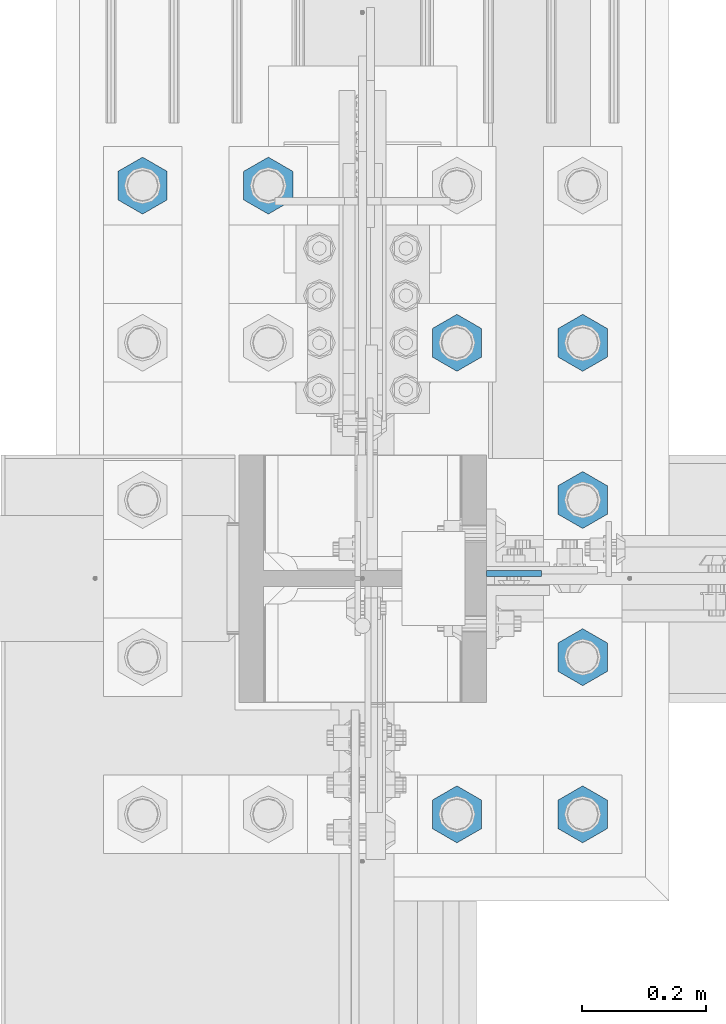
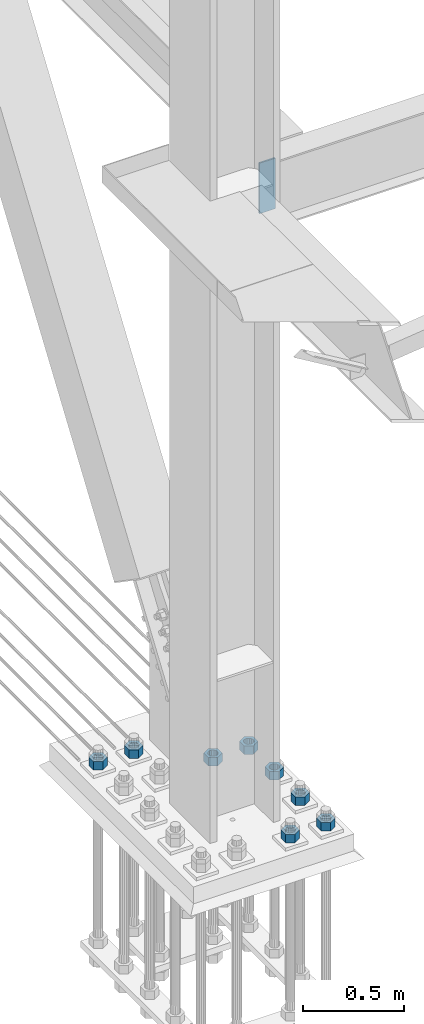
# One storey, part 1548 of 3843: 9 columns, 2 elements without a shape of their own.
"""IFC2X3 building model written with IfcOpenShell, lengths in millimetres."""

from ifc_helpers import new_model, si_unit, frame, origin_with_axes, place, context, subcontext, project, spatial, faceted_brep, material, type_object, element, aggregate, save


model = new_model("IFC2X3")

# Units and contexts
model_context = context("Model", 3, precision=1e-05, world=origin_with_axes())
body_context = subcontext(model_context, "Body", "Model", "MODEL_VIEW")
ifc_project = project(units=[si_unit("LENGTHUNIT", "METRE", prefix="MILLI"), si_unit("AREAUNIT", "SQUARE_METRE"), si_unit("VOLUMEUNIT", "CUBIC_METRE"), si_unit("MASSUNIT", "GRAM", prefix="KILO"), si_unit("TIMEUNIT", "SECOND"), si_unit("PLANEANGLEUNIT", "RADIAN"), si_unit("SOLIDANGLEUNIT", "STERADIAN"), si_unit("THERMODYNAMICTEMPERATUREUNIT", "DEGREE_CELSIUS"), si_unit("LUMINOUSINTENSITYUNIT", "LUMEN")], contexts=[model_context])

# Site, building, storey
site_placement = place(None, origin_with_axes())
site = spatial("IfcSite", under=ifc_project, at=site_placement, CompositionType="ELEMENT")
building_placement = place(site_placement, origin_with_axes())
building = spatial("IfcBuilding", under=site, at=building_placement, Name="Undefined", CompositionType="ELEMENT")
storey_placement = place(building_placement, origin_with_axes())
storey = spatial("IfcBuildingStorey", under=building, at=storey_placement, Name="Undefined", CompositionType="ELEMENT", Elevation=0.0)

# Assembly, column
assembly_1_placement = place(storey_placement, origin_with_axes())
assembly_1 = element("IfcElementAssembly", 1, at=assembly_1_placement, inside=storey, Name="COLUMN", AssemblyPlace="NOTDEFINED", PredefinedType="RIGID_FRAME")
ifc_material = material(Name="STEEL/A572-50")
column_type_1 = type_object("IfcColumnType", PredefinedType="NOTDEFINED")
column_1_placement = place(assembly_1_placement, frame((36820.475, 67279.8375, 33693.0999993376), z_axis=(-1.0, 0.0, 0.0), x_axis=(0.0, 0.0, 1.0)))
column_1 = element("IfcColumn", 2, at=column_1_placement, type_object=column_type_1, material=ifc_material, Name="PLATE", context=body_context, shape_type="Brep", body=[
    faceted_brep([(0.0, 4.76249999999709, -44.4500000000007), (0.0, 4.76249999999709, 44.4500000000007), (304.799999999996, 4.76249999999709, 44.4500000000007), (304.799999999996, 4.76249999999709, -44.4500000000007), (0.0, -4.76249999999709, 44.4500000000007), (304.799999999996, -4.76249999999709, 44.4500000000007), (0.0, -4.76249999999709, -44.4500000000007), (304.799999999996, -4.76249999999709, -44.4500000000007)], [[[0, 1, 2, 3]], [[1, 4, 5, 2]], [[4, 6, 7, 5]], [[6, 0, 3, 7]], [[5, 7, 3, 2]], [[6, 4, 1, 0]]]),
])
aggregate(assembly_1, [column_1])

# Assembly, columns
assembly_2_placement = place(storey_placement, origin_with_axes())
assembly_2 = element("IfcElementAssembly", 3, at=assembly_2_placement, inside=storey, Name="TEMPLATE", AssemblyPlace="NOTDEFINED", PredefinedType="RIGID_FRAME")
column_type_2 = type_object("IfcColumnType", Name="2_HEAVY_HEX_NUT", PredefinedType="NOTDEFINED")
column_2_placement = place(assembly_2_placement, frame((36931.6, 66890.9, 30232.35), z_axis=(1.0, 0.0, 0.0), x_axis=(0.0, 0.0, -1.0)))
column_2 = element("IfcColumn", 4, at=column_2_placement, type_object=column_type_2, material=ifc_material, Name="NUT", ObjectType="2_HEAVY_HEX_NUT", context=body_context, shape_type="Brep", body=[
    faceted_brep([(0.0, -46.0369987487793, 0.0), (0.0, -23.0184993743896, -39.869213104248), (50.7999999999993, -23.0184993743896, -39.869213104248), (50.7999999999993, -46.0369987487793, 0.0), (0.0, 23.0184993743896, -39.869213104248), (50.7999999999993, 23.0184993743896, -39.869213104248), (0.0, 46.0369987487793, 0.0), (50.7999999999993, 46.0369987487793, 0.0), (0.0, 23.0184993743896, 39.869213104248), (50.7999999999993, 23.0184993743896, 39.869213104248), (0.0, -23.0184993743896, 39.869213104248), (50.7999999999993, -23.0184993743896, 39.869213104248), (0.0, 0.0, 26.1940002441406), (0.0, 11.3650617044477, 23.5999013092805), (50.7999999999993, 11.3650617044477, 23.5999013092805), (50.7999999999993, 0.0, 26.1940002441406), (0.0, 20.4791109456419, 16.3316083006721), (50.7999999999993, 20.4791109456419, 16.3316083006721), (0.0, 25.5370200498292, 5.82867859874386), (50.7999999999993, 25.5370200498292, 5.82867859874386), (0.0, 25.5370200498292, -5.82867859874386), (50.7999999999993, 25.5370200498292, -5.82867859874386), (0.0, 20.4791109456419, -16.3316083006721), (50.7999999999993, 20.4791109456419, -16.3316083006721), (0.0, 11.3650617044477, -23.5999013092805), (50.7999999999993, 11.3650617044477, -23.5999013092805), (0.0, 0.0, -26.1940002441406), (50.7999999999993, 0.0, -26.1940002441406), (0.0, -11.3650617044477, -23.5999013092805), (50.7999999999993, -11.3650617044477, -23.5999013092805), (0.0, -20.4791109456419, -16.3316083006721), (50.7999999999993, -20.4791109456419, -16.3316083006721), (0.0, -25.5370200498292, -5.82867859874386), (50.7999999999993, -25.5370200498292, -5.82867859874386), (0.0, -25.5370200498292, 5.82867859874386), (50.7999999999993, -25.5370200498292, 5.82867859874386), (0.0, -20.4791109456419, 16.3316083006721), (50.7999999999993, -20.4791109456419, 16.3316083006721), (0.0, -11.3650617044477, 23.5999013092805), (50.7999999999993, -11.3650617044477, 23.5999013092805)], [[[0, 1, 2, 3]], [[1, 4, 5, 2]], [[4, 6, 7, 5]], [[6, 8, 9, 7]], [[8, 10, 11, 9]], [[10, 0, 3, 11]], [[12, 13, 14, 15]], [[13, 16, 17, 14]], [[16, 18, 19, 17]], [[18, 20, 21, 19]], [[20, 22, 23, 21]], [[22, 24, 25, 23]], [[24, 26, 27, 25]], [[26, 28, 29, 27]], [[28, 30, 31, 29]], [[30, 32, 33, 31]], [[32, 34, 35, 33]], [[34, 36, 37, 35]], [[36, 38, 39, 37]], [[38, 12, 15, 39]], [[5, 7, 9, 11, 3, 2], [17, 19, 21, 23, 25, 27, 29, 31, 33, 35, 37, 39, 15, 14]], [[10, 8, 6, 4, 1, 0], [38, 36, 34, 32, 30, 28, 26, 24, 22, 20, 18, 16, 13, 12]]]),
])
column_3_placement = place(assembly_2_placement, frame((36931.6, 67144.9, 30232.35), z_axis=(1.0, 0.0, 0.0), x_axis=(0.0, 0.0, -1.0)))
column_3 = element("IfcColumn", 5, at=column_3_placement, type_object=column_type_2, material=ifc_material, Name="NUT", ObjectType="2_HEAVY_HEX_NUT", context=body_context, shape_type="Brep", body=[
    faceted_brep([(0.0, -46.0369987487793, 0.0), (0.0, -23.0184993743896, -39.869213104248), (50.7999999999993, -23.0184993743896, -39.869213104248), (50.7999999999993, -46.0369987487793, 0.0), (0.0, 23.0184993743896, -39.869213104248), (50.7999999999993, 23.0184993743896, -39.869213104248), (0.0, 46.0369987487793, 0.0), (50.7999999999993, 46.0369987487793, 0.0), (0.0, 23.0184993743896, 39.869213104248), (50.7999999999993, 23.0184993743896, 39.869213104248), (0.0, -23.0184993743896, 39.869213104248), (50.7999999999993, -23.0184993743896, 39.869213104248), (0.0, 0.0, 26.1940002441406), (0.0, 11.3650617044477, 23.5999013092805), (50.7999999999993, 11.3650617044477, 23.5999013092805), (50.7999999999993, 0.0, 26.1940002441406), (0.0, 20.4791109456419, 16.3316083006721), (50.7999999999993, 20.4791109456419, 16.3316083006721), (0.0, 25.5370200498292, 5.82867859874386), (50.7999999999993, 25.5370200498292, 5.82867859874386), (0.0, 25.5370200498292, -5.82867859874386), (50.7999999999993, 25.5370200498292, -5.82867859874386), (0.0, 20.4791109456419, -16.3316083006721), (50.7999999999993, 20.4791109456419, -16.3316083006721), (0.0, 11.3650617044477, -23.5999013092805), (50.7999999999993, 11.3650617044477, -23.5999013092805), (0.0, 0.0, -26.1940002441406), (50.7999999999993, 0.0, -26.1940002441406), (0.0, -11.3650617044477, -23.5999013092805), (50.7999999999993, -11.3650617044477, -23.5999013092805), (0.0, -20.4791109456419, -16.3316083006721), (50.7999999999993, -20.4791109456419, -16.3316083006721), (0.0, -25.5370200498292, -5.82867859874386), (50.7999999999993, -25.5370200498292, -5.82867859874386), (0.0, -25.5370200498292, 5.82867859874386), (50.7999999999993, -25.5370200498292, 5.82867859874386), (0.0, -20.4791109456419, 16.3316083006721), (50.7999999999993, -20.4791109456419, 16.3316083006721), (0.0, -11.3650617044477, 23.5999013092805), (50.7999999999993, -11.3650617044477, 23.5999013092805)], [[[0, 1, 2, 3]], [[1, 4, 5, 2]], [[4, 6, 7, 5]], [[6, 8, 9, 7]], [[8, 10, 11, 9]], [[10, 0, 3, 11]], [[12, 13, 14, 15]], [[13, 16, 17, 14]], [[16, 18, 19, 17]], [[18, 20, 21, 19]], [[20, 22, 23, 21]], [[22, 24, 25, 23]], [[24, 26, 27, 25]], [[26, 28, 29, 27]], [[28, 30, 31, 29]], [[30, 32, 33, 31]], [[32, 34, 35, 33]], [[34, 36, 37, 35]], [[36, 38, 39, 37]], [[38, 12, 15, 39]], [[5, 7, 9, 11, 3, 2], [17, 19, 21, 23, 25, 27, 29, 31, 33, 35, 37, 39, 15, 14]], [[10, 8, 6, 4, 1, 0], [38, 36, 34, 32, 30, 28, 26, 24, 22, 20, 18, 16, 13, 12]]]),
])
column_4_placement = place(assembly_2_placement, frame((36931.6, 67398.9, 30232.35), z_axis=(1.0, 0.0, 0.0), x_axis=(0.0, 0.0, -1.0)))
column_4 = element("IfcColumn", 6, at=column_4_placement, type_object=column_type_2, material=ifc_material, Name="NUT", ObjectType="2_HEAVY_HEX_NUT", context=body_context, shape_type="Brep", body=[
    faceted_brep([(0.0, -46.0369987487793, 0.0), (0.0, -23.0184993743896, -39.869213104248), (50.7999999999993, -23.0184993743896, -39.869213104248), (50.7999999999993, -46.0369987487793, 0.0), (0.0, 23.0184993743896, -39.869213104248), (50.7999999999993, 23.0184993743896, -39.869213104248), (0.0, 46.0369987487793, 0.0), (50.7999999999993, 46.0369987487793, 0.0), (0.0, 23.0184993743896, 39.869213104248), (50.7999999999993, 23.0184993743896, 39.869213104248), (0.0, -23.0184993743896, 39.869213104248), (50.7999999999993, -23.0184993743896, 39.869213104248), (0.0, 0.0, 26.1940002441406), (0.0, 11.3650617044477, 23.5999013092805), (50.7999999999993, 11.3650617044477, 23.5999013092805), (50.7999999999993, 0.0, 26.1940002441406), (0.0, 20.4791109456419, 16.3316083006721), (50.7999999999993, 20.4791109456419, 16.3316083006721), (0.0, 25.5370200498292, 5.82867859874386), (50.7999999999993, 25.5370200498292, 5.82867859874386), (0.0, 25.5370200498292, -5.82867859874386), (50.7999999999993, 25.5370200498292, -5.82867859874386), (0.0, 20.4791109456419, -16.3316083006721), (50.7999999999993, 20.4791109456419, -16.3316083006721), (0.0, 11.3650617044477, -23.5999013092805), (50.7999999999993, 11.3650617044477, -23.5999013092805), (0.0, 0.0, -26.1940002441406), (50.7999999999993, 0.0, -26.1940002441406), (0.0, -11.3650617044477, -23.5999013092805), (50.7999999999993, -11.3650617044477, -23.5999013092805), (0.0, -20.4791109456419, -16.3316083006721), (50.7999999999993, -20.4791109456419, -16.3316083006721), (0.0, -25.5370200498292, -5.82867859874386), (50.7999999999993, -25.5370200498292, -5.82867859874386), (0.0, -25.5370200498292, 5.82867859874386), (50.7999999999993, -25.5370200498292, 5.82867859874386), (0.0, -20.4791109456419, 16.3316083006721), (50.7999999999993, -20.4791109456419, 16.3316083006721), (0.0, -11.3650617044477, 23.5999013092805), (50.7999999999993, -11.3650617044477, 23.5999013092805)], [[[0, 1, 2, 3]], [[1, 4, 5, 2]], [[4, 6, 7, 5]], [[6, 8, 9, 7]], [[8, 10, 11, 9]], [[10, 0, 3, 11]], [[12, 13, 14, 15]], [[13, 16, 17, 14]], [[16, 18, 19, 17]], [[18, 20, 21, 19]], [[20, 22, 23, 21]], [[22, 24, 25, 23]], [[24, 26, 27, 25]], [[26, 28, 29, 27]], [[28, 30, 31, 29]], [[30, 32, 33, 31]], [[32, 34, 35, 33]], [[34, 36, 37, 35]], [[36, 38, 39, 37]], [[38, 12, 15, 39]], [[5, 7, 9, 11, 3, 2], [17, 19, 21, 23, 25, 27, 29, 31, 33, 35, 37, 39, 15, 14]], [[10, 8, 6, 4, 1, 0], [38, 36, 34, 32, 30, 28, 26, 24, 22, 20, 18, 16, 13, 12]]]),
])
column_5_placement = place(assembly_2_placement, frame((36931.6, 67652.9, 30232.35), z_axis=(-1.0, 0.0, 0.0), x_axis=(0.0, 0.0, -1.0)))
column_5 = element("IfcColumn", 7, at=column_5_placement, type_object=column_type_2, material=ifc_material, Name="NUT", ObjectType="2_HEAVY_HEX_NUT", context=body_context, shape_type="Brep", body=[
    faceted_brep([(0.0, -46.0369987487793, 0.0), (0.0, -23.0184993743896, -39.869213104248), (50.7999999999993, -23.0184993743896, -39.869213104248), (50.7999999999993, -46.0369987487793, 0.0), (0.0, 23.0184993743896, -39.869213104248), (50.7999999999993, 23.0184993743896, -39.869213104248), (0.0, 46.0369987487793, 0.0), (50.7999999999993, 46.0369987487793, 0.0), (0.0, 23.0184993743896, 39.869213104248), (50.7999999999993, 23.0184993743896, 39.869213104248), (0.0, -23.0184993743896, 39.869213104248), (50.7999999999993, -23.0184993743896, 39.869213104248), (0.0, 0.0, 26.1940002441406), (0.0, 11.3650617044477, 23.5999013092805), (50.7999999999993, 11.3650617044477, 23.5999013092805), (50.7999999999993, 0.0, 26.1940002441406), (0.0, 20.4791109456419, 16.3316083006721), (50.7999999999993, 20.4791109456419, 16.3316083006721), (0.0, 25.5370200498292, 5.82867859874386), (50.7999999999993, 25.5370200498292, 5.82867859874386), (0.0, 25.5370200498292, -5.82867859874386), (50.7999999999993, 25.5370200498292, -5.82867859874386), (0.0, 20.4791109456419, -16.3316083006721), (50.7999999999993, 20.4791109456419, -16.3316083006721), (0.0, 11.3650617044477, -23.5999013092805), (50.7999999999993, 11.3650617044477, -23.5999013092805), (0.0, 0.0, -26.1940002441406), (50.7999999999993, 0.0, -26.1940002441406), (0.0, -11.3650617044477, -23.5999013092805), (50.7999999999993, -11.3650617044477, -23.5999013092805), (0.0, -20.4791109456419, -16.3316083006721), (50.7999999999993, -20.4791109456419, -16.3316083006721), (0.0, -25.5370200498292, -5.82867859874386), (50.7999999999993, -25.5370200498292, -5.82867859874386), (0.0, -25.5370200498292, 5.82867859874386), (50.7999999999993, -25.5370200498292, 5.82867859874386), (0.0, -20.4791109456419, 16.3316083006721), (50.7999999999993, -20.4791109456419, 16.3316083006721), (0.0, -11.3650617044477, 23.5999013092805), (50.7999999999993, -11.3650617044477, 23.5999013092805)], [[[0, 1, 2, 3]], [[1, 4, 5, 2]], [[4, 6, 7, 5]], [[6, 8, 9, 7]], [[8, 10, 11, 9]], [[10, 0, 3, 11]], [[12, 13, 14, 15]], [[13, 16, 17, 14]], [[16, 18, 19, 17]], [[18, 20, 21, 19]], [[20, 22, 23, 21]], [[22, 24, 25, 23]], [[24, 26, 27, 25]], [[26, 28, 29, 27]], [[28, 30, 31, 29]], [[30, 32, 33, 31]], [[32, 34, 35, 33]], [[34, 36, 37, 35]], [[36, 38, 39, 37]], [[38, 12, 15, 39]], [[5, 7, 9, 11, 3, 2], [17, 19, 21, 23, 25, 27, 29, 31, 33, 35, 37, 39, 15, 14]], [[10, 8, 6, 4, 1, 0], [38, 36, 34, 32, 30, 28, 26, 24, 22, 20, 18, 16, 13, 12]]]),
])
column_6_placement = place(assembly_2_placement, frame((36728.4, 66890.9, 30232.35), z_axis=(1.0, 0.0, 0.0), x_axis=(0.0, 0.0, -1.0)))
column_6 = element("IfcColumn", 8, at=column_6_placement, type_object=column_type_2, material=ifc_material, Name="NUT", ObjectType="2_HEAVY_HEX_NUT", context=body_context, shape_type="Brep", body=[
    faceted_brep([(0.0, -46.0369987487793, 0.0), (0.0, -23.0184993743896, -39.869213104248), (50.7999999999993, -23.0184993743896, -39.869213104248), (50.7999999999993, -46.0369987487793, 0.0), (0.0, 23.0184993743896, -39.869213104248), (50.7999999999993, 23.0184993743896, -39.869213104248), (0.0, 46.0369987487793, 0.0), (50.7999999999993, 46.0369987487793, 0.0), (0.0, 23.0184993743896, 39.869213104248), (50.7999999999993, 23.0184993743896, 39.869213104248), (0.0, -23.0184993743896, 39.869213104248), (50.7999999999993, -23.0184993743896, 39.869213104248), (0.0, 0.0, 26.1940002441406), (0.0, 11.3650617044477, 23.5999013092805), (50.7999999999993, 11.3650617044477, 23.5999013092805), (50.7999999999993, 0.0, 26.1940002441406), (0.0, 20.4791109456419, 16.3316083006721), (50.7999999999993, 20.4791109456419, 16.3316083006721), (0.0, 25.5370200498292, 5.82867859874386), (50.7999999999993, 25.5370200498292, 5.82867859874386), (0.0, 25.5370200498292, -5.82867859874386), (50.7999999999993, 25.5370200498292, -5.82867859874386), (0.0, 20.4791109456419, -16.3316083006721), (50.7999999999993, 20.4791109456419, -16.3316083006721), (0.0, 11.3650617044477, -23.5999013092805), (50.7999999999993, 11.3650617044477, -23.5999013092805), (0.0, 0.0, -26.1940002441406), (50.7999999999993, 0.0, -26.1940002441406), (0.0, -11.3650617044477, -23.5999013092805), (50.7999999999993, -11.3650617044477, -23.5999013092805), (0.0, -20.4791109456419, -16.3316083006721), (50.7999999999993, -20.4791109456419, -16.3316083006721), (0.0, -25.5370200498292, -5.82867859874386), (50.7999999999993, -25.5370200498292, -5.82867859874386), (0.0, -25.5370200498292, 5.82867859874386), (50.7999999999993, -25.5370200498292, 5.82867859874386), (0.0, -20.4791109456419, 16.3316083006721), (50.7999999999993, -20.4791109456419, 16.3316083006721), (0.0, -11.3650617044477, 23.5999013092805), (50.7999999999993, -11.3650617044477, 23.5999013092805)], [[[0, 1, 2, 3]], [[1, 4, 5, 2]], [[4, 6, 7, 5]], [[6, 8, 9, 7]], [[8, 10, 11, 9]], [[10, 0, 3, 11]], [[12, 13, 14, 15]], [[13, 16, 17, 14]], [[16, 18, 19, 17]], [[18, 20, 21, 19]], [[20, 22, 23, 21]], [[22, 24, 25, 23]], [[24, 26, 27, 25]], [[26, 28, 29, 27]], [[28, 30, 31, 29]], [[30, 32, 33, 31]], [[32, 34, 35, 33]], [[34, 36, 37, 35]], [[36, 38, 39, 37]], [[38, 12, 15, 39]], [[5, 7, 9, 11, 3, 2], [17, 19, 21, 23, 25, 27, 29, 31, 33, 35, 37, 39, 15, 14]], [[10, 8, 6, 4, 1, 0], [38, 36, 34, 32, 30, 28, 26, 24, 22, 20, 18, 16, 13, 12]]]),
])
column_7_placement = place(assembly_2_placement, frame((36728.4, 67652.9, 30232.35), z_axis=(-1.0, 0.0, 0.0), x_axis=(0.0, 0.0, -1.0)))
column_7 = element("IfcColumn", 9, at=column_7_placement, type_object=column_type_2, material=ifc_material, Name="NUT", ObjectType="2_HEAVY_HEX_NUT", context=body_context, shape_type="Brep", body=[
    faceted_brep([(0.0, -46.0369987487793, 0.0), (0.0, -23.0184993743896, -39.869213104248), (50.7999999999993, -23.0184993743896, -39.869213104248), (50.7999999999993, -46.0369987487793, 0.0), (0.0, 23.0184993743896, -39.869213104248), (50.7999999999993, 23.0184993743896, -39.869213104248), (0.0, 46.0369987487793, 0.0), (50.7999999999993, 46.0369987487793, 0.0), (0.0, 23.0184993743896, 39.869213104248), (50.7999999999993, 23.0184993743896, 39.869213104248), (0.0, -23.0184993743896, 39.869213104248), (50.7999999999993, -23.0184993743896, 39.869213104248), (0.0, 0.0, 26.1940002441406), (0.0, 11.3650617044477, 23.5999013092805), (50.7999999999993, 11.3650617044477, 23.5999013092805), (50.7999999999993, 0.0, 26.1940002441406), (0.0, 20.4791109456419, 16.3316083006721), (50.7999999999993, 20.4791109456419, 16.3316083006721), (0.0, 25.5370200498292, 5.82867859874386), (50.7999999999993, 25.5370200498292, 5.82867859874386), (0.0, 25.5370200498292, -5.82867859874386), (50.7999999999993, 25.5370200498292, -5.82867859874386), (0.0, 20.4791109456419, -16.3316083006721), (50.7999999999993, 20.4791109456419, -16.3316083006721), (0.0, 11.3650617044477, -23.5999013092805), (50.7999999999993, 11.3650617044477, -23.5999013092805), (0.0, 0.0, -26.1940002441406), (50.7999999999993, 0.0, -26.1940002441406), (0.0, -11.3650617044477, -23.5999013092805), (50.7999999999993, -11.3650617044477, -23.5999013092805), (0.0, -20.4791109456419, -16.3316083006721), (50.7999999999993, -20.4791109456419, -16.3316083006721), (0.0, -25.5370200498292, -5.82867859874386), (50.7999999999993, -25.5370200498292, -5.82867859874386), (0.0, -25.5370200498292, 5.82867859874386), (50.7999999999993, -25.5370200498292, 5.82867859874386), (0.0, -20.4791109456419, 16.3316083006721), (50.7999999999993, -20.4791109456419, 16.3316083006721), (0.0, -11.3650617044477, 23.5999013092805), (50.7999999999993, -11.3650617044477, 23.5999013092805)], [[[0, 1, 2, 3]], [[1, 4, 5, 2]], [[4, 6, 7, 5]], [[6, 8, 9, 7]], [[8, 10, 11, 9]], [[10, 0, 3, 11]], [[12, 13, 14, 15]], [[13, 16, 17, 14]], [[16, 18, 19, 17]], [[18, 20, 21, 19]], [[20, 22, 23, 21]], [[22, 24, 25, 23]], [[24, 26, 27, 25]], [[26, 28, 29, 27]], [[28, 30, 31, 29]], [[30, 32, 33, 31]], [[32, 34, 35, 33]], [[34, 36, 37, 35]], [[36, 38, 39, 37]], [[38, 12, 15, 39]], [[5, 7, 9, 11, 3, 2], [17, 19, 21, 23, 25, 27, 29, 31, 33, 35, 37, 39, 15, 14]], [[10, 8, 6, 4, 1, 0], [38, 36, 34, 32, 30, 28, 26, 24, 22, 20, 18, 16, 13, 12]]]),
])
column_8_placement = place(assembly_2_placement, frame((36423.6, 67906.9, 30232.35), z_axis=(-1.0, 0.0, 0.0), x_axis=(0.0, 0.0, -1.0)))
column_8 = element("IfcColumn", 10, at=column_8_placement, type_object=column_type_2, material=ifc_material, Name="NUT", ObjectType="2_HEAVY_HEX_NUT", context=body_context, shape_type="Brep", body=[
    faceted_brep([(0.0, -46.0369987487793, 0.0), (0.0, -23.0184993743896, -39.869213104248), (50.7999999999993, -23.0184993743896, -39.869213104248), (50.7999999999993, -46.0369987487793, 0.0), (0.0, 23.0184993743896, -39.869213104248), (50.7999999999993, 23.0184993743896, -39.869213104248), (0.0, 46.0369987487793, 0.0), (50.7999999999993, 46.0369987487793, 0.0), (0.0, 23.0184993743896, 39.869213104248), (50.7999999999993, 23.0184993743896, 39.869213104248), (0.0, -23.0184993743896, 39.869213104248), (50.7999999999993, -23.0184993743896, 39.869213104248), (0.0, 0.0, 26.1940002441406), (0.0, 11.3650617044477, 23.5999013092805), (50.7999999999993, 11.3650617044477, 23.5999013092805), (50.7999999999993, 0.0, 26.1940002441406), (0.0, 20.4791109456419, 16.3316083006721), (50.7999999999993, 20.4791109456419, 16.3316083006721), (0.0, 25.5370200498292, 5.82867859874386), (50.7999999999993, 25.5370200498292, 5.82867859874386), (0.0, 25.5370200498292, -5.82867859874386), (50.7999999999993, 25.5370200498292, -5.82867859874386), (0.0, 20.4791109456419, -16.3316083006721), (50.7999999999993, 20.4791109456419, -16.3316083006721), (0.0, 11.3650617044477, -23.5999013092805), (50.7999999999993, 11.3650617044477, -23.5999013092805), (0.0, 0.0, -26.1940002441406), (50.7999999999993, 0.0, -26.1940002441406), (0.0, -11.3650617044477, -23.5999013092805), (50.7999999999993, -11.3650617044477, -23.5999013092805), (0.0, -20.4791109456419, -16.3316083006721), (50.7999999999993, -20.4791109456419, -16.3316083006721), (0.0, -25.5370200498292, -5.82867859874386), (50.7999999999993, -25.5370200498292, -5.82867859874386), (0.0, -25.5370200498292, 5.82867859874386), (50.7999999999993, -25.5370200498292, 5.82867859874386), (0.0, -20.4791109456419, 16.3316083006721), (50.7999999999993, -20.4791109456419, 16.3316083006721), (0.0, -11.3650617044477, 23.5999013092805), (50.7999999999993, -11.3650617044477, 23.5999013092805)], [[[0, 1, 2, 3]], [[1, 4, 5, 2]], [[4, 6, 7, 5]], [[6, 8, 9, 7]], [[8, 10, 11, 9]], [[10, 0, 3, 11]], [[12, 13, 14, 15]], [[13, 16, 17, 14]], [[16, 18, 19, 17]], [[18, 20, 21, 19]], [[20, 22, 23, 21]], [[22, 24, 25, 23]], [[24, 26, 27, 25]], [[26, 28, 29, 27]], [[28, 30, 31, 29]], [[30, 32, 33, 31]], [[32, 34, 35, 33]], [[34, 36, 37, 35]], [[36, 38, 39, 37]], [[38, 12, 15, 39]], [[5, 7, 9, 11, 3, 2], [17, 19, 21, 23, 25, 27, 29, 31, 33, 35, 37, 39, 15, 14]], [[10, 8, 6, 4, 1, 0], [38, 36, 34, 32, 30, 28, 26, 24, 22, 20, 18, 16, 13, 12]]]),
])
column_9_placement = place(assembly_2_placement, frame((36220.4, 67906.9, 30232.35), z_axis=(-1.0, 0.0, 0.0), x_axis=(0.0, 0.0, -1.0)))
column_9 = element("IfcColumn", 11, at=column_9_placement, type_object=column_type_2, material=ifc_material, Name="NUT", ObjectType="2_HEAVY_HEX_NUT", context=body_context, shape_type="Brep", body=[
    faceted_brep([(0.0, -46.0369987487793, 0.0), (0.0, -23.0184993743896, -39.869213104248), (50.7999999999993, -23.0184993743896, -39.869213104248), (50.7999999999993, -46.0369987487793, 0.0), (0.0, 23.0184993743896, -39.869213104248), (50.7999999999993, 23.0184993743896, -39.869213104248), (0.0, 46.0369987487793, 0.0), (50.7999999999993, 46.0369987487793, 0.0), (0.0, 23.0184993743896, 39.869213104248), (50.7999999999993, 23.0184993743896, 39.869213104248), (0.0, -23.0184993743896, 39.869213104248), (50.7999999999993, -23.0184993743896, 39.869213104248), (0.0, 0.0, 26.1940002441406), (0.0, 11.3650617044477, 23.5999013092805), (50.7999999999993, 11.3650617044477, 23.5999013092805), (50.7999999999993, 0.0, 26.1940002441406), (0.0, 20.4791109456419, 16.3316083006721), (50.7999999999993, 20.4791109456419, 16.3316083006721), (0.0, 25.5370200498292, 5.82867859874386), (50.7999999999993, 25.5370200498292, 5.82867859874386), (0.0, 25.5370200498292, -5.82867859874386), (50.7999999999993, 25.5370200498292, -5.82867859874386), (0.0, 20.4791109456419, -16.3316083006721), (50.7999999999993, 20.4791109456419, -16.3316083006721), (0.0, 11.3650617044477, -23.5999013092805), (50.7999999999993, 11.3650617044477, -23.5999013092805), (0.0, 0.0, -26.1940002441406), (50.7999999999993, 0.0, -26.1940002441406), (0.0, -11.3650617044477, -23.5999013092805), (50.7999999999993, -11.3650617044477, -23.5999013092805), (0.0, -20.4791109456419, -16.3316083006721), (50.7999999999993, -20.4791109456419, -16.3316083006721), (0.0, -25.5370200498292, -5.82867859874386), (50.7999999999993, -25.5370200498292, -5.82867859874386), (0.0, -25.5370200498292, 5.82867859874386), (50.7999999999993, -25.5370200498292, 5.82867859874386), (0.0, -20.4791109456419, 16.3316083006721), (50.7999999999993, -20.4791109456419, 16.3316083006721), (0.0, -11.3650617044477, 23.5999013092805), (50.7999999999993, -11.3650617044477, 23.5999013092805)], [[[0, 1, 2, 3]], [[1, 4, 5, 2]], [[4, 6, 7, 5]], [[6, 8, 9, 7]], [[8, 10, 11, 9]], [[10, 0, 3, 11]], [[12, 13, 14, 15]], [[13, 16, 17, 14]], [[16, 18, 19, 17]], [[18, 20, 21, 19]], [[20, 22, 23, 21]], [[22, 24, 25, 23]], [[24, 26, 27, 25]], [[26, 28, 29, 27]], [[28, 30, 31, 29]], [[30, 32, 33, 31]], [[32, 34, 35, 33]], [[34, 36, 37, 35]], [[36, 38, 39, 37]], [[38, 12, 15, 39]], [[5, 7, 9, 11, 3, 2], [17, 19, 21, 23, 25, 27, 29, 31, 33, 35, 37, 39, 15, 14]], [[10, 8, 6, 4, 1, 0], [38, 36, 34, 32, 30, 28, 26, 24, 22, 20, 18, 16, 13, 12]]]),
])
aggregate(assembly_2, [column_2, column_3, column_4, column_5, column_6, column_7, column_8, column_9])

save(model, "model.ifc")
